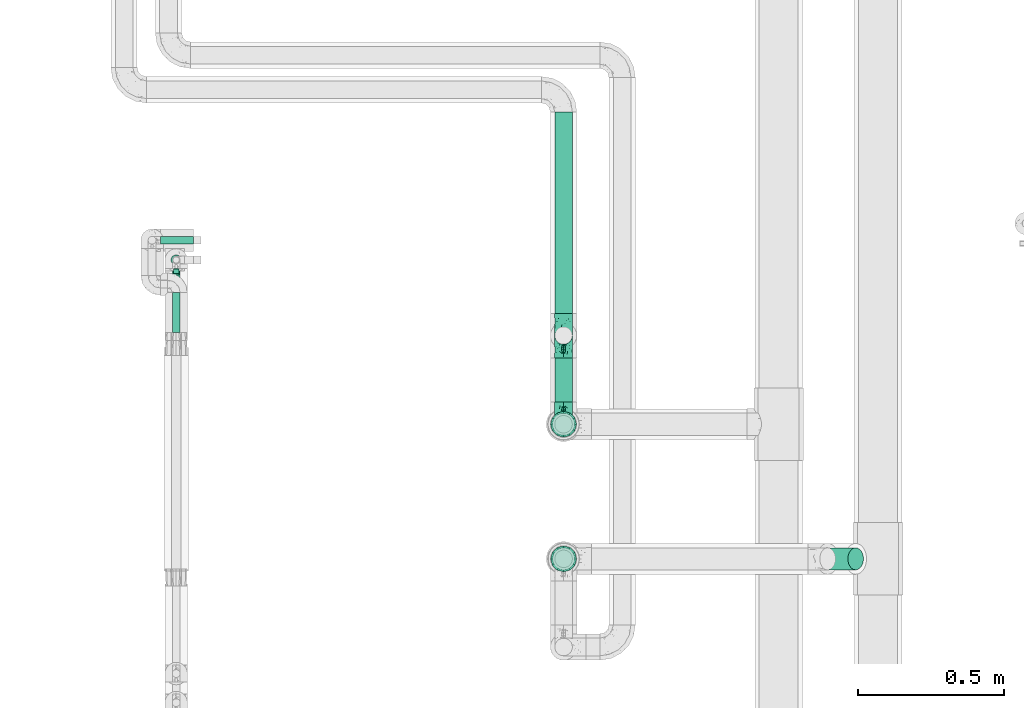
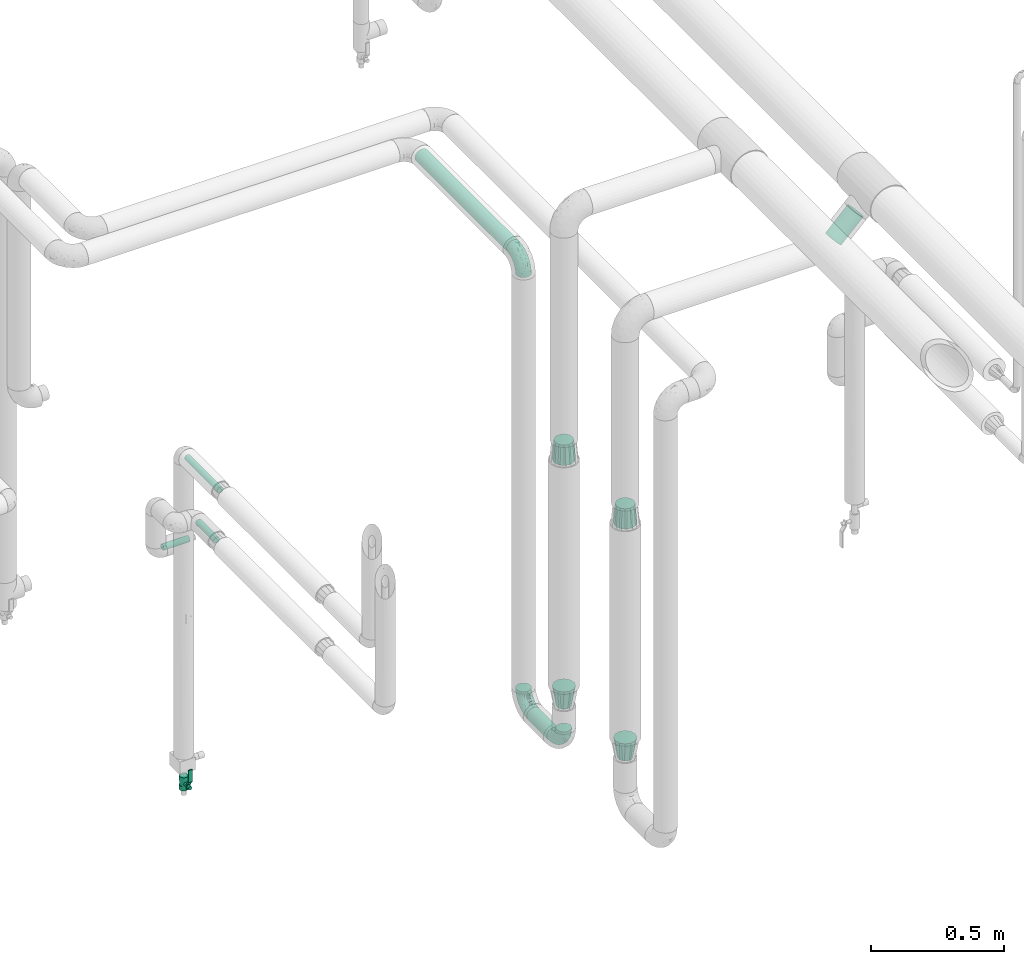
# One storey, part 554 of 827: 7 flow fittings, 6 flow segments, 1 flow controller.
"""IFC2X3 building model written with IfcOpenShell, lengths in millimetres."""

from ifc_helpers import new_model, entity, si_unit, converted_unit, derived_unit, direction, frame, origin, origin_2d_with_axis, place, context, subcontext, project, spatial, polyline, circle, outline, extrude, faceted_brep, source, transform, mapped, material, material_list, type_object, type_shapes, element, save


model = new_model("IFC2X3")

# Units and contexts
model_context = context("Model", 3, precision=0.01, world=origin(), true_north=direction((6.12303176911189e-17, 1.0)))
body_context = subcontext(model_context, "Body", "Model", "MODEL_VIEW")
ifc_project = project(units=[si_unit("LENGTHUNIT", "METRE", prefix="MILLI"), si_unit("AREAUNIT", "SQUARE_METRE"), si_unit("VOLUMEUNIT", "CUBIC_METRE"), converted_unit("PLANEANGLEUNIT", "DEGREE", entity("IfcRatioMeasure", 0.0174532925199433), si_unit("PLANEANGLEUNIT", "RADIAN"), dimensions=[0, 0, 0, 0, 0, 0, 0]), si_unit("MASSUNIT", "GRAM", prefix="KILO"), derived_unit("MASSDENSITYUNIT", [(si_unit("MASSUNIT", "GRAM", prefix="KILO"), 1), (si_unit("LENGTHUNIT", "METRE"), -3)]), derived_unit("MOMENTOFINERTIAUNIT", [(si_unit("LENGTHUNIT", "METRE"), 4)]), si_unit("TIMEUNIT", "SECOND"), si_unit("FREQUENCYUNIT", "HERTZ"), si_unit("THERMODYNAMICTEMPERATUREUNIT", "DEGREE_CELSIUS"), derived_unit("THERMALTRANSMITTANCEUNIT", [(si_unit("MASSUNIT", "GRAM", prefix="KILO"), 1), (si_unit("THERMODYNAMICTEMPERATUREUNIT", "KELVIN"), -1), (si_unit("TIMEUNIT", "SECOND"), -3)]), derived_unit("VOLUMETRICFLOWRATEUNIT", [(si_unit("LENGTHUNIT", "METRE"), 3), (si_unit("TIMEUNIT", "SECOND"), -1)]), derived_unit("MASSFLOWRATEUNIT", [(si_unit("MASSUNIT", "GRAM", prefix="KILO"), 1), (si_unit("TIMEUNIT", "SECOND"), -1)]), derived_unit("ROTATIONALFREQUENCYUNIT", [(si_unit("TIMEUNIT", "SECOND"), -1)]), si_unit("ELECTRICCURRENTUNIT", "AMPERE"), si_unit("ELECTRICVOLTAGEUNIT", "VOLT"), si_unit("POWERUNIT", "WATT"), si_unit("FORCEUNIT", "NEWTON", prefix="KILO"), si_unit("ILLUMINANCEUNIT", "LUX"), si_unit("LUMINOUSFLUXUNIT", "LUMEN"), si_unit("LUMINOUSINTENSITYUNIT", "CANDELA"), derived_unit("USERDEFINED", [(si_unit("MASSUNIT", "GRAM", prefix="KILO"), -1), (si_unit("LENGTHUNIT", "METRE"), -2), (si_unit("TIMEUNIT", "SECOND"), 3), (si_unit("LUMINOUSFLUXUNIT", "LUMEN"), 1)]), derived_unit("LINEARVELOCITYUNIT", [(si_unit("LENGTHUNIT", "METRE"), 1), (si_unit("TIMEUNIT", "SECOND"), -1)]), si_unit("PRESSUREUNIT", "PASCAL"), derived_unit("USERDEFINED", [(si_unit("LENGTHUNIT", "METRE"), -2), (si_unit("MASSUNIT", "GRAM", prefix="KILO"), 1), (si_unit("TIMEUNIT", "SECOND"), -2)]), derived_unit("LINEARFORCEUNIT", [(si_unit("MASSUNIT", "GRAM", prefix="KILO"), 1), (si_unit("LENGTHUNIT", "METRE"), 1), (si_unit("TIMEUNIT", "SECOND"), -2), (si_unit("LENGTHUNIT", "METRE"), -1)]), derived_unit("PLANARFORCEUNIT", [(si_unit("MASSUNIT", "GRAM", prefix="KILO"), 1), (si_unit("LENGTHUNIT", "METRE"), 1), (si_unit("TIMEUNIT", "SECOND"), -2), (si_unit("LENGTHUNIT", "METRE"), -2)])], contexts=[model_context])

# Site, building, storey
site_placement = place(None, origin())
site = spatial("IfcSite", under=ifc_project, at=site_placement, CompositionType="ELEMENT")
building_placement = place(site_placement, origin())
building = spatial("IfcBuilding", under=site, at=building_placement, CompositionType="ELEMENT")
storey_placement = place(building_placement, frame((0.0, 0.0, 28200.0)))
storey = spatial("IfcBuildingStorey", under=building, at=storey_placement, Name="08", CompositionType="ELEMENT", Elevation=28200.0)

# Flow segments
pipe_segment_type = type_object("IfcPipeSegmentType", PredefinedType="NOTDEFINED")
flow_segment_1_placement = place(storey_placement, frame((21068.46, 11638.86, 2368.4)))
element("IfcFlowSegment", 1, at=flow_segment_1_placement, inside=storey, type_object=pipe_segment_type, context=body_context, shape_type="SweptSolid", body=[
    extrude(circle(Radius=30.0, at=origin_2d_with_axis()), frame((31.6, 0.0, 31.6), z_axis=(0.0, 1.0, 0.0), x_axis=(-1.0, 0.0, 0.0)), (0.0, 0.0, 1.0), 687.999999999989),
])
flow_segment_2_placement = place(storey_placement, frame((21068.46, 11335.65, 318.41)))
element("IfcFlowSegment", 2, at=flow_segment_2_placement, inside=storey, type_object=pipe_segment_type, context=body_context, shape_type="SweptSolid", body=[
    extrude(circle(Radius=30.0, at=origin_2d_with_axis()), frame((31.6, 0.0, 31.6), z_axis=(0.0, 1.0, 0.0), x_axis=(-1.0, 0.0, 0.0)), (0.0, 0.0, 1.0), 151.217153558148),
])
flow_segment_3_placement = place(storey_placement, frame((19761.27, 11546.06, 1789.58)))
element("IfcFlowSegment", 3, at=flow_segment_3_placement, inside=storey, type_object=pipe_segment_type, context=body_context, shape_type="SweptSolid", body=[
    extrude(circle(Radius=13.4, at=origin_2d_with_axis()), frame((15.0, 0.0, 15.0), z_axis=(0.0, 1.0, 0.0), x_axis=(-1.0, 0.0, 0.0)), (0.0, 0.0, 1.0), 245.900000000016),
])
flow_segment_4_placement = place(storey_placement, frame((19722.87, 11873.56, 1337.95)))
element("IfcFlowSegment", 4, at=flow_segment_4_placement, inside=storey, type_object=pipe_segment_type, context=body_context, shape_type="SweptSolid", body=[
    extrude(circle(Radius=13.4, at=origin_2d_with_axis()), frame((0.0, 15.0, 15.0), z_axis=(1.0, 0.0, 0.0), x_axis=(0.0, -1.0, 0.0)), (0.0, 0.0, 1.0), 112.500000000009),
])
flow_segment_5_placement = place(storey_placement, frame((19761.27, 11573.56, 1543.17)))
element("IfcFlowSegment", 5, at=flow_segment_5_placement, inside=storey, type_object=pipe_segment_type, context=body_context, shape_type="SweptSolid", body=[
    extrude(circle(Radius=13.4, at=origin_2d_with_axis()), frame((15.0, 0.0, 15.0), z_axis=(0.0, 1.0, 0.0), x_axis=(-1.0, 0.0, 0.0)), (0.0, 0.0, 1.0), 135.899999999993),
])
flow_segment_6_placement = place(storey_placement, frame((21974.37, 10760.3, 2599.54)))
element("IfcFlowSegment", 6, at=flow_segment_6_placement, inside=storey, type_object=pipe_segment_type, context=body_context, shape_type="SweptSolid", body=[
    extrude(circle(Radius=37.75, at=origin_2d_with_axis()), frame((28.29, 39.35, 28.29), z_axis=(0.7071067811865, 0.0, 0.707106781186596), x_axis=(0.0, 1.0, 0.0)), (0.0, 0.0, 1.0), 135.393152079012),
])

# Flow controller
ifc_material = material()
ifc_material_list = material_list([ifc_material, ifc_material, ifc_material, ifc_material, ifc_material])
valve_type = type_object("IfcValveType", PredefinedType="NOTDEFINED", material=ifc_material_list)
shared_shape_1 = source(origin(), body_context, "Body", "SweptSolid", [
    extrude(circle(Radius=17.5, at=origin_2d_with_axis()), frame((-30.5, 0.0, 0.0), z_axis=(1.0, 0.0, 0.0), x_axis=(0.0, 1.0, 0.0)), (0.0, 0.0, 1.0), 20.3333333333333),
    extrude(circle(Radius=16.0, at=origin_2d_with_axis()), frame((-10.17, 0.0, 0.0), z_axis=(1.0, 0.0, 0.0), x_axis=(0.0, 1.0, 0.0)), (0.0, 0.0, 1.0), 20.3333333333333),
    extrude(circle(Radius=17.5, at=origin_2d_with_axis()), frame((10.17, 0.0, 0.0), z_axis=(1.0, 0.0, 0.0), x_axis=(0.0, 1.0, 0.0)), (0.0, 0.0, 1.0), 20.3333333333333),
    extrude(outline(polyline([(-38.75, -5.0), (-38.75, -10.0), (-17.92, -10.0), (2.08, 5.0), (56.25, 5.0), (56.25, 10.0), (0.42, 10.0), (-19.58, -5.0), (-38.75, -5.0)])), frame((28.75, -8.75, 41.5), z_axis=(0.0, -1.0, 0.0), x_axis=(1.0, 0.0, 0.0)), (0.0, 0.0, -1.0), 17.5),
    extrude(circle(Radius=8.0, at=origin_2d_with_axis()), origin(), (0.0, 0.0, 1.0), 49.0),
])
type_shapes(valve_type, [shared_shape_1])
flow_controller_placement = place(storey_placement, frame((19776.27, 11821.06, 300.0), z_axis=(0.0, -1.0, 0.0), x_axis=(0.0, 0.0, 1.0)))
element("IfcFlowController", 7, at=flow_controller_placement, inside=storey, type_object=valve_type, material=ifc_material, context=body_context, shape_type="MappedRepresentation", body=[
    mapped(shared_shape_1, transform((0.0, 0.0, 0.0), scale=1.0)),
])

# Flow fittings
pipe_fitting_type_1 = type_object("IfcPipeFittingType", Name="ADSK_1", PredefinedType="NOTDEFINED", material=ifc_material)
shared_shape_2 = source(origin(), body_context, "Body", "Brep", [
    faceted_brep([(-76.0, 15.07, -26.11), (-76.0, 7.8, -29.12), (-76.0, 0.0, -30.15), (-76.0, -7.8, -29.12), (-76.0, -15.08, -26.11), (-76.0, -21.32, -21.32), (-76.0, -26.11, -15.08), (-76.0, -29.12, -7.8), (-76.0, -30.15, 0.0), (-76.0, -29.12, 7.8), (-76.0, -26.11, 15.07), (-76.0, -21.32, 21.32), (-76.0, -15.08, 26.11), (-76.0, -7.8, 29.12), (-76.0, 0.0, 30.15), (-76.0, 7.8, 29.12), (-76.0, 15.07, 26.11), (-76.0, 21.32, 21.32), (-76.0, 26.11, 15.07), (-76.0, 29.12, 7.8), (-76.0, 30.15, 0.0), (-76.0, 29.12, -7.8), (-76.0, 26.11, -15.08), (-76.0, 21.32, -21.32), (0.0, 76.0, -30.15), (-7.8, 76.0, -29.12), (-15.07, 76.0, -26.11), (-21.32, 76.0, -21.32), (-26.11, 76.0, -15.08), (-29.12, 76.0, -7.8), (-30.15, 76.0, 0.0), (-29.12, 76.0, 7.8), (-26.11, 76.0, 15.07), (-21.32, 76.0, 21.32), (-15.07, 76.0, 26.11), (-7.8, 76.0, 29.12), (0.0, 76.0, 30.15), (7.8, 76.0, 29.12), (15.08, 76.0, 26.11), (21.32, 76.0, 21.32), (26.11, 76.0, 15.07), (29.12, 76.0, 7.8), (30.15, 76.0, 0.0), (29.12, 76.0, -7.8), (26.11, 76.0, -15.08), (21.32, 76.0, -21.32), (15.08, 76.0, -26.11), (7.8, 76.0, -29.12), (10.79, 31.43, 21.07), (4.32, 31.7, 25.72), (1.65, 15.19, 19.92), (-61.17, -27.8, 0.0), (-51.1, -25.49, 9.84), (-56.14, -10.61, 27.27), (-31.7, -4.32, 25.72), (-39.75, 1.72, 29.41), (-43.2, -24.95, 0.0), (-1.86, 1.86, 0.0), (4.49, 7.65, 5.78), (-7.82, -4.61, 5.83), (-56.21, -22.79, 17.21), (-58.98, -3.38, 29.7), (-53.96, 5.6, 30.07), (-10.86, 10.86, 25.48), (-17.2, -2.6, 20.44), (-49.15, -16.01, 22.7), (-22.18, -14.24, 7.99), (-28.4, -17.42, 0.0), (-13.61, -9.88, 0.0), (-39.0, 23.48, 27.76), (-58.76, 12.54, 28.36), (-41.61, 15.41, 29.48), (16.01, 49.15, 22.7), (-58.55, 25.93, 19.53), (-51.53, 33.5, 13.51), (-64.92, 28.76, 12.4), (-7.48, 23.14, 28.25), (-1.72, 39.75, 29.41), (-12.04, 27.88, 29.88), (-63.91, 18.81, 24.52), (-11.63, 65.16, 28.18), (-4.97, 57.02, 30.05), (9.88, 13.61, 0.0), (-62.5, 31.74, 5.02), (-45.17, 30.98, 21.2), (-21.78, 9.76, 28.58), (10.61, 56.14, 27.27), (-32.09, 54.42, 13.26), (22.79, 56.21, 17.21), (15.38, 31.17, 15.63), (25.49, 51.1, 9.84), (21.84, 36.35, 5.92), (24.95, 43.2, 0.0), (3.38, 58.98, 29.7), (-31.17, -15.38, 15.63), (-39.39, 41.78, 15.45), (-34.56, 41.13, 20.79), (-39.81, -23.25, 5.49), (27.8, 61.17, 0.0), (-31.74, 62.5, 5.02), (-53.07, 36.29, 0.0), (-42.95, 42.95, 7.29), (-36.29, 53.07, 0.0), (-19.83, 58.51, 24.79), (-25.48, 60.2, 19.41), (-14.53, 50.96, 28.57), (-13.31, 37.09, 30.07), (-26.16, 40.06, 26.4), (-32.43, -10.35, 21.9), (17.42, 28.4, 0.0), (14.24, 22.18, 7.99), (-38.67, 9.72, 30.15), (-24.66, 17.36, 30.09), (-37.08, 31.49, 24.99), (-49.27, 22.83, 25.24), (-20.8, 38.81, 28.63), (-27.58, 27.58, 29.2), (-36.07, -20.23, 10.71), (-15.19, -6.16, 14.9), (6.6, 15.4, 14.49), (-2.51, 2.51, 11.35), (-65.16, 11.63, -28.18), (-49.15, -16.01, -22.7), (-57.02, 4.97, -30.05), (-25.93, 58.55, -19.53), (-33.5, 51.53, -13.51), (-28.76, 64.92, -12.4), (-60.2, 25.48, -19.41), (-58.51, 19.83, -24.79), (4.61, 7.82, -5.83), (-7.65, -4.49, -5.78), (-2.51, 2.51, -11.35), (-62.5, 31.74, -5.02), (-50.96, 14.53, -28.57), (-37.09, 13.31, -30.07), (-42.95, 42.95, -7.29), (25.49, 51.1, -9.84), (22.79, 56.21, -17.21), (-40.06, 26.16, -26.4), (3.38, 58.98, -29.7), (-5.6, 53.96, -30.07), (-27.88, 12.04, -29.88), (-9.76, 21.78, -28.58), (-23.14, 7.48, -28.25), (-51.1, -25.49, -9.84), (15.38, 31.17, -15.63), (16.01, 49.15, -22.7), (-23.48, 39.0, -27.76), (-12.54, 58.76, -28.36), (-15.41, 41.61, -29.48), (-56.21, -22.79, -17.21), (-9.72, 38.67, -30.15), (-17.36, 24.66, -30.09), (-22.18, -14.24, -7.99), (-41.13, 34.56, -20.79), (-31.74, 62.5, -5.02), (-58.98, -3.38, -29.7), (-31.17, -15.38, -15.63), (-56.14, -10.61, -27.27), (14.24, 22.18, -7.99), (23.25, 39.81, -5.49), (-31.49, 37.08, -24.99), (-15.19, -6.16, -14.9), (1.65, 15.19, -19.92), (-18.81, 63.91, -24.52), (-32.59, -11.62, -20.84), (-31.7, -4.32, -25.72), (-17.2, -2.6, -20.44), (-39.75, 1.72, -29.41), (-54.42, 32.09, -13.26), (-30.98, 45.17, -21.2), (10.61, 56.14, -27.27), (10.23, 31.31, -21.52), (4.32, 31.7, -25.72), (-41.78, 39.39, -15.45), (-1.72, 39.75, -29.41), (-36.35, -21.84, -5.92), (-22.83, 49.27, -25.24), (-38.81, 20.8, -28.63), (-27.58, 27.58, -29.2), (-10.86, 10.86, -25.48), (20.23, 36.07, -10.71), (6.6, 15.4, -14.49)], [[[0, 1, 2, 3, 4, 5, 6, 7, 8, 9, 10, 11, 12, 13, 14, 15, 16, 17, 18, 19, 20, 21, 22, 23]], [[24, 25, 26, 27, 28, 29, 30, 31, 32, 33, 34, 35, 36, 37, 38, 39, 40, 41, 42, 43, 44, 45, 46, 47]], [[48, 49, 50]], [[51, 52, 9]], [[53, 54, 55]], [[9, 52, 10]], [[56, 52, 51]], [[57, 58, 59]], [[11, 10, 60]], [[14, 61, 62]], [[63, 54, 64]], [[65, 12, 11]], [[65, 53, 12]], [[66, 67, 68]], [[69, 70, 71]], [[72, 39, 38]], [[73, 74, 75]], [[15, 70, 16]], [[76, 77, 78]], [[16, 79, 17]], [[13, 61, 14]], [[35, 80, 81]], [[14, 62, 15]], [[17, 73, 18]], [[57, 82, 58]], [[20, 19, 83]], [[75, 19, 18]], [[70, 15, 62]], [[73, 84, 74]], [[78, 85, 76]], [[38, 86, 72]], [[32, 31, 87]], [[88, 89, 90]], [[91, 92, 90]], [[72, 86, 49]], [[36, 93, 37]], [[75, 83, 19]], [[36, 35, 81]], [[60, 94, 65]], [[40, 90, 41]], [[95, 96, 87]], [[88, 90, 40]], [[66, 97, 67]], [[90, 98, 41]], [[40, 39, 88]], [[99, 31, 30]], [[20, 83, 100]], [[101, 102, 100]], [[52, 60, 10]], [[102, 99, 30]], [[96, 103, 104]], [[83, 101, 100]], [[12, 53, 13]], [[104, 103, 33]], [[105, 106, 81]], [[107, 105, 103]], [[64, 54, 108]], [[80, 103, 105]], [[80, 35, 34]], [[34, 33, 103]], [[86, 38, 37]], [[109, 110, 82]], [[71, 111, 112]], [[69, 107, 113]], [[79, 73, 17]], [[114, 113, 84]], [[33, 32, 104]], [[115, 107, 116]], [[105, 115, 106]], [[93, 81, 77]], [[54, 53, 65]], [[61, 53, 55]], [[108, 94, 64]], [[54, 63, 85]], [[93, 86, 37]], [[77, 76, 49]], [[77, 49, 86]], [[49, 63, 50]], [[60, 52, 117]], [[65, 11, 60]], [[39, 72, 88]], [[89, 88, 72]], [[71, 70, 62]], [[79, 70, 114]], [[103, 96, 107]], [[69, 113, 114]], [[112, 106, 116]], [[77, 81, 106]], [[112, 116, 71]], [[112, 55, 85]], [[64, 50, 63]], [[57, 59, 68]], [[32, 87, 104]], [[96, 104, 87]], [[94, 118, 64]], [[50, 119, 89]], [[50, 64, 118]], [[50, 89, 48]], [[81, 93, 36]], [[86, 93, 77]], [[53, 61, 13]], [[62, 61, 55]], [[71, 62, 111]], [[69, 71, 116]], [[95, 101, 74]], [[99, 101, 87]], [[118, 66, 59]], [[117, 97, 66]], [[117, 66, 94]], [[91, 89, 110]], [[91, 110, 109]], [[110, 89, 119]], [[9, 8, 51]], [[98, 90, 92]], [[98, 42, 41]], [[101, 83, 74]], [[101, 99, 102]], [[87, 31, 99]], [[62, 55, 111]], [[55, 112, 111]], [[107, 69, 116]], [[70, 69, 114]], [[107, 96, 113]], [[84, 113, 96]], [[84, 96, 95]], [[114, 84, 73]], [[70, 79, 16]], [[73, 79, 114]], [[54, 85, 55]], [[76, 85, 63]], [[49, 76, 63]], [[77, 106, 78]], [[106, 112, 78]], [[85, 78, 112]], [[73, 75, 18]], [[83, 75, 74]], [[103, 80, 34]], [[81, 80, 105]], [[101, 95, 87]], [[84, 95, 74]], [[106, 115, 116]], [[105, 107, 115]], [[120, 59, 58]], [[82, 110, 58]], [[119, 58, 110]], [[118, 59, 120]], [[66, 68, 59]], [[54, 65, 108]], [[94, 108, 65]], [[66, 118, 94]], [[50, 118, 120]], [[50, 120, 119]], [[119, 120, 58]], [[89, 72, 48]], [[49, 48, 72]], [[60, 117, 94]], [[117, 52, 97]], [[52, 56, 97]], [[67, 97, 56]], [[92, 91, 109]], [[89, 91, 90]], [[121, 1, 0]], [[122, 5, 4]], [[2, 1, 123]], [[124, 125, 126]], [[127, 128, 23]], [[129, 130, 131]], [[100, 132, 20]], [[133, 134, 123]], [[135, 100, 102]], [[136, 137, 44]], [[133, 128, 138]], [[24, 139, 140]], [[141, 142, 143]], [[121, 128, 133]], [[6, 144, 7]], [[137, 145, 146]], [[144, 51, 7]], [[147, 148, 149]], [[144, 6, 150]], [[149, 151, 152]], [[153, 68, 67]], [[154, 128, 127]], [[30, 155, 102]], [[43, 42, 98]], [[156, 3, 2]], [[157, 144, 150]], [[158, 4, 3]], [[24, 140, 25]], [[155, 135, 102]], [[159, 160, 109]], [[30, 29, 155]], [[147, 138, 161]], [[27, 124, 28]], [[57, 129, 82]], [[162, 163, 131]], [[27, 26, 164]], [[148, 26, 25]], [[165, 166, 167]], [[24, 47, 139]], [[143, 168, 141]], [[22, 21, 169]], [[125, 124, 170]], [[148, 25, 140]], [[46, 146, 171]], [[158, 122, 4]], [[0, 23, 128]], [[1, 121, 123]], [[109, 82, 159]], [[45, 44, 137]], [[146, 46, 45]], [[136, 43, 98]], [[132, 21, 20]], [[136, 98, 92]], [[172, 173, 146]], [[46, 171, 47]], [[43, 136, 44]], [[174, 154, 169]], [[171, 173, 175]], [[6, 5, 150]], [[126, 29, 28]], [[176, 56, 144]], [[122, 158, 166]], [[164, 124, 27]], [[177, 161, 170]], [[23, 22, 127]], [[178, 138, 179]], [[133, 178, 134]], [[156, 123, 168]], [[156, 158, 3]], [[168, 143, 166]], [[168, 166, 158]], [[166, 180, 167]], [[173, 171, 146]], [[139, 171, 175]], [[172, 145, 163]], [[173, 180, 142]], [[5, 122, 150]], [[157, 150, 122]], [[137, 136, 181]], [[146, 45, 137]], [[149, 148, 140]], [[164, 148, 177]], [[128, 154, 138]], [[147, 161, 177]], [[152, 134, 179]], [[168, 123, 134]], [[152, 179, 149]], [[152, 175, 142]], [[57, 130, 129]], [[157, 165, 167]], [[22, 169, 127]], [[154, 127, 169]], [[163, 167, 180]], [[162, 157, 167]], [[173, 163, 180]], [[182, 163, 145]], [[123, 156, 2]], [[158, 156, 168]], [[171, 139, 47]], [[140, 139, 175]], [[149, 140, 151]], [[147, 149, 179]], [[174, 135, 125]], [[132, 135, 169]], [[176, 157, 153]], [[176, 153, 67]], [[153, 157, 162]], [[182, 159, 129]], [[181, 160, 159]], [[181, 159, 145]], [[51, 144, 56]], [[51, 8, 7]], [[135, 132, 100]], [[169, 21, 132]], [[126, 155, 29]], [[135, 155, 125]], [[140, 175, 151]], [[175, 152, 151]], [[138, 147, 179]], [[148, 147, 177]], [[138, 154, 161]], [[170, 161, 154]], [[170, 154, 174]], [[177, 170, 124]], [[148, 164, 26]], [[124, 164, 177]], [[173, 142, 175]], [[143, 142, 180]], [[166, 143, 180]], [[168, 134, 141]], [[134, 152, 141]], [[142, 141, 152]], [[124, 126, 28]], [[155, 126, 125]], [[128, 121, 0]], [[123, 121, 133]], [[135, 174, 169]], [[170, 174, 125]], [[134, 178, 179]], [[133, 138, 178]], [[130, 153, 162]], [[68, 153, 130]], [[57, 68, 130]], [[182, 129, 131]], [[159, 82, 129]], [[157, 122, 165]], [[166, 165, 122]], [[163, 162, 167]], [[162, 131, 130]], [[145, 172, 146]], [[163, 173, 172]], [[159, 182, 145]], [[131, 163, 182]], [[56, 176, 67]], [[157, 176, 144]], [[137, 181, 145]], [[181, 136, 160]], [[136, 92, 160]], [[109, 160, 92]]]),
])
type_shapes(pipe_fitting_type_1, [shared_shape_2])
for number, where, z_axis, x_axis, name in (
    (8, (21100.05, 11562.86, 2400.0), (1.0, 0.0, 0.0), (0.0, -1.0, 0.0), "ADSK_1"),
    (9, (21100.05, 11562.86, 350.01), (-1.0, 0.0, 0.0), (0.0, 0.0, -1.0), "ADSK_1"),
    (10, (21100.05, 11259.65, 350.01), (-1.0, 0.0, 0.0), (0.0, -1.0, 0.0), "ADSK_1"),
):
    element("IfcFlowFitting", number, at=place(storey_placement, frame(where, z_axis=z_axis, x_axis=x_axis)), inside=storey, type_object=pipe_fitting_type_1, material=ifc_material, Name=name, ObjectType="ADSK_1", context=body_context, shape_type="MappedRepresentation", body=[
        mapped(shared_shape_2, transform((0.0, 0.0, 0.0), scale=1.0)),
    ])
pipe_fitting_type_2 = type_object("IfcPipeFittingType", Name="ADSK_1", PredefinedType="NOTDEFINED", material=ifc_material)
shared_shape_3 = source(origin(), body_context, "Body", "Brep", [
    faceted_brep([(89.0, -44.45, 0.0), (89.0, -41.96, -9.31), (89.0, -38.49, -22.22), (89.0, -30.36, -30.36), (89.0, -22.23, -38.49), (89.0, -11.11, -41.47), (89.0, 0.0, -44.45), (89.0, 11.11, -41.47), (89.0, 22.22, -38.49), (89.0, 30.36, -30.36), (89.0, 38.49, -22.22), (89.0, 41.96, -9.31), (89.0, 44.45, 0.0), (89.0, 41.96, 9.31), (89.0, 38.49, 22.23), (89.0, 30.36, 30.36), (89.0, 22.22, 38.49), (89.0, 11.11, 41.47), (89.0, 0.0, 44.45), (89.0, -11.11, 41.47), (89.0, -22.23, 38.49), (89.0, -30.36, 30.36), (89.0, -38.49, 22.23), (89.0, -41.96, 9.31), (0.0, 38.05, 0.0), (0.0, 35.5, -9.51), (0.0, 32.95, -19.02), (0.0, 25.99, -25.99), (0.0, 19.02, -32.95), (0.0, 9.51, -35.5), (0.0, 0.0, -38.05), (0.0, -9.51, -35.5), (0.0, -19.03, -32.95), (0.0, -25.99, -25.99), (0.0, -32.95, -19.02), (0.0, -35.5, -9.51), (0.0, -38.05, 0.0), (0.0, -35.5, 9.51), (0.0, -32.95, 19.03), (0.0, -25.99, 25.99), (0.0, -19.03, 32.95), (0.0, -9.51, 35.5), (0.0, 0.0, 38.05), (0.0, 9.51, 35.5), (0.0, 19.03, 32.95), (0.0, 25.99, 25.99), (0.0, 32.95, 19.03), (0.0, 35.5, 9.51)], [[[0, 1, 2, 3, 4, 5, 6, 7, 8, 9, 10, 11, 12, 13, 14, 15, 16, 17, 18, 19, 20, 21, 22, 23]], [[24, 25, 26, 27, 28, 29, 30, 31, 32, 33, 34, 35, 36, 37, 38, 39, 40, 41, 42, 43, 44, 45, 46, 47]], [[2, 1, 0, 36, 35, 34]], [[28, 8, 7, 6, 30, 29]], [[32, 4, 3, 2, 34, 33]], [[5, 4, 32, 31, 30, 6]], [[10, 26, 25, 24, 12, 11]], [[9, 8, 28, 27, 26, 10]], [[14, 13, 12, 24, 47, 46]], [[40, 20, 19, 18, 42, 41]], [[44, 16, 15, 14, 46, 45]], [[17, 16, 44, 43, 42, 18]], [[22, 38, 37, 36, 0, 23]], [[21, 20, 40, 39, 38, 22]]]),
])
type_shapes(pipe_fitting_type_2, [shared_shape_3])
flow_fitting_1_placement = place(storey_placement, frame((21100.05, 11259.65, 1745.76), z_axis=(1.0, 0.0, 0.0), x_axis=(0.0, 0.0, -1.0)))
element("IfcFlowFitting", 11, at=flow_fitting_1_placement, inside=storey, type_object=pipe_fitting_type_2, material=ifc_material, Name="ADSK_1", ObjectType="ADSK_1", context=body_context, shape_type="MappedRepresentation", body=[
    mapped(shared_shape_3, transform((0.0, 0.0, 0.0), scale=1.0)),
])
pipe_fitting_type_3 = type_object("IfcPipeFittingType", Name="ADSK_1", PredefinedType="NOTDEFINED", material=ifc_material)
shared_shape_4 = source(origin(), body_context, "Body", "Brep", [
    faceted_brep([(89.0, 38.05, 0.0), (89.0, 35.5, 9.51), (89.0, 32.95, 19.03), (89.0, 25.99, 25.99), (89.0, 19.02, 32.95), (89.0, 9.51, 35.5), (89.0, 0.0, 38.05), (89.0, -9.51, 35.5), (89.0, -19.03, 32.95), (89.0, -25.99, 25.99), (89.0, -32.95, 19.03), (89.0, -35.5, 9.51), (89.0, -38.05, 0.0), (89.0, -35.5, -9.51), (89.0, -32.95, -19.02), (89.0, -25.99, -25.99), (89.0, -19.03, -32.95), (89.0, -9.51, -35.5), (89.0, 0.0, -38.05), (89.0, 9.51, -35.5), (89.0, 19.02, -32.95), (89.0, 25.99, -25.99), (89.0, 32.95, -19.03), (89.0, 35.5, -9.51), (0.0, -38.49, 22.22), (0.0, -30.36, 30.36), (0.0, -22.22, 38.49), (0.0, -11.11, 41.47), (0.0, 0.0, 44.45), (0.0, 11.11, 41.47), (0.0, 22.23, 38.49), (0.0, 30.36, 30.36), (0.0, 38.49, 22.22), (0.0, 41.96, 9.31), (0.0, 44.45, 0.0), (0.0, 41.47, -11.11), (0.0, 38.49, -22.23), (0.0, 30.36, -30.36), (0.0, 22.23, -38.49), (0.0, 11.11, -41.47), (0.0, 0.0, -44.45), (0.0, -11.11, -41.47), (0.0, -22.23, -38.49), (0.0, -30.36, -30.36), (0.0, -38.49, -22.23), (0.0, -41.96, -9.31), (0.0, -44.45, 0.0), (0.0, -41.47, 11.11)], [[[0, 1, 2, 3, 4, 5, 6, 7, 8, 9, 10, 11, 12, 13, 14, 15, 16, 17, 18, 19, 20, 21, 22, 23]], [[24, 25, 26, 27, 28, 29, 30, 31, 32, 33, 34, 35, 36, 37, 38, 39, 40, 41, 42, 43, 44, 45, 46, 47]], [[23, 22, 36, 35, 34, 0]], [[39, 38, 20, 19, 18, 40]], [[38, 37, 36, 22, 21, 20]], [[43, 42, 16, 15, 14, 44]], [[41, 40, 18, 17, 16, 42]], [[12, 46, 45, 44, 14, 13]], [[11, 10, 24, 47, 46, 12]], [[27, 26, 8, 7, 6, 28]], [[26, 25, 24, 10, 9, 8]], [[31, 30, 4, 3, 2, 32]], [[29, 28, 6, 5, 4, 30]], [[0, 34, 33, 32, 2, 1]]]),
])
type_shapes(pipe_fitting_type_3, [shared_shape_4])
flow_fitting_2_placement = place(storey_placement, frame((21100.29, 10799.65, 1643.85), z_axis=(1.0, 0.0, 0.0), x_axis=(0.0, 0.0, 1.0)))
element("IfcFlowFitting", 12, at=flow_fitting_2_placement, inside=storey, type_object=pipe_fitting_type_3, material=ifc_material, Name="ADSK_1", ObjectType="ADSK_1", context=body_context, shape_type="MappedRepresentation", body=[
    mapped(shared_shape_4, transform((0.0, 0.0, 0.0), scale=1.0)),
])
pipe_fitting_type_4 = type_object("IfcPipeFittingType", Name="ADSK_1", PredefinedType="NOTDEFINED", material=ifc_material)
shared_shape_5 = source(origin(), body_context, "Body", "Brep", [
    faceted_brep([(89.0, -24.39, 17.72), (89.0, -27.27, 8.86), (89.0, -30.15, 0.0), (89.0, -27.27, -8.86), (89.0, -24.39, -17.72), (89.0, -16.85, -23.2), (89.0, -9.32, -28.67), (89.0, 0.0, -28.67), (89.0, 9.32, -28.67), (89.0, 16.85, -23.2), (89.0, 24.39, -17.72), (89.0, 27.27, -8.86), (89.0, 30.15, 0.0), (89.0, 27.27, 8.86), (89.0, 24.39, 17.72), (89.0, 16.85, 23.2), (89.0, 9.32, 28.67), (89.0, 0.0, 28.67), (89.0, -9.32, 28.67), (89.0, -16.85, 23.2), (0.0, 11.11, 41.47), (0.0, 22.22, 38.49), (0.0, 30.36, 30.36), (0.0, 38.49, 22.23), (0.0, 42.1, 8.76), (0.0, 44.45, 0.0), (0.0, 42.1, -8.76), (0.0, 38.49, -22.23), (0.0, 30.36, -30.36), (0.0, 22.23, -38.49), (0.0, 11.11, -41.47), (0.0, 0.0, -44.45), (0.0, -11.11, -41.47), (0.0, -22.23, -38.49), (0.0, -30.36, -30.36), (0.0, -38.49, -22.22), (0.0, -42.1, -8.76), (0.0, -44.45, 0.0), (0.0, -42.1, 8.76), (0.0, -38.49, 22.22), (0.0, -30.36, 30.36), (0.0, -22.22, 38.49), (0.0, -11.11, 41.47), (0.0, 0.0, 44.45)], [[[0, 1, 2, 3, 4, 5, 6, 7, 8, 9, 10, 11, 12, 13, 14, 15, 16, 17, 18, 19]], [[20, 21, 22, 23, 24, 25, 26, 27, 28, 29, 30, 31, 32, 33, 34, 35, 36, 37, 38, 39, 40, 41, 42, 43]], [[28, 9, 29]], [[27, 10, 28]], [[9, 28, 10]], [[27, 11, 10]], [[26, 12, 11]], [[33, 6, 5]], [[9, 8, 29]], [[30, 29, 8]], [[6, 32, 7]], [[8, 7, 30]], [[4, 34, 5]], [[2, 37, 36]], [[32, 31, 7]], [[2, 36, 3]], [[27, 26, 11]], [[6, 33, 32]], [[12, 26, 25]], [[3, 35, 4]], [[4, 35, 34]], [[35, 3, 36]], [[33, 5, 34]], [[30, 7, 31]], [[40, 19, 41]], [[39, 0, 40]], [[19, 40, 0]], [[39, 1, 0]], [[38, 2, 1]], [[21, 16, 15]], [[19, 18, 41]], [[42, 41, 18]], [[16, 20, 17]], [[18, 17, 42]], [[14, 22, 15]], [[12, 25, 24]], [[20, 43, 17]], [[12, 24, 13]], [[39, 38, 1]], [[16, 21, 20]], [[2, 38, 37]], [[13, 23, 14]], [[14, 23, 22]], [[23, 13, 24]], [[21, 15, 22]], [[42, 17, 43]]]),
])
type_shapes(pipe_fitting_type_4, [shared_shape_5])
for number, where, z_axis, x_axis, name in (
    (13, (21100.05, 11259.65, 619.0), (1.0, 0.0, 0.0), (0.0, 0.0, -1.0), "ADSK_1"),
    (14, (21100.29, 10799.65, 660.26), (1.0, 0.0, 0.0), (0.0, 0.0, -1.0), "ADSK_1"),
):
    element("IfcFlowFitting", number, at=place(storey_placement, frame(where, z_axis=z_axis, x_axis=x_axis)), inside=storey, type_object=pipe_fitting_type_4, material=ifc_material, Name=name, ObjectType="ADSK_1", context=body_context, shape_type="MappedRepresentation", body=[
        mapped(shared_shape_5, transform((0.0, 0.0, 0.0), scale=1.0)),
    ])

save(model, "model.ifc")
